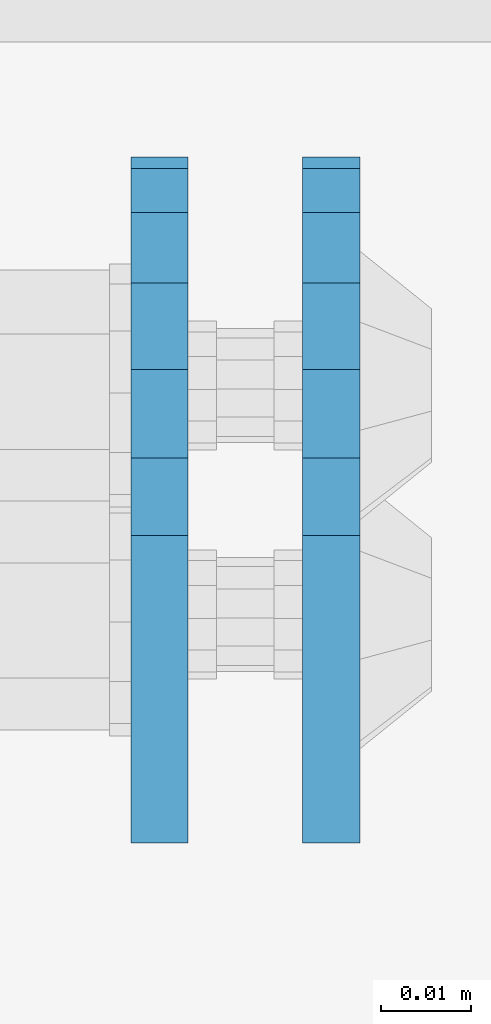
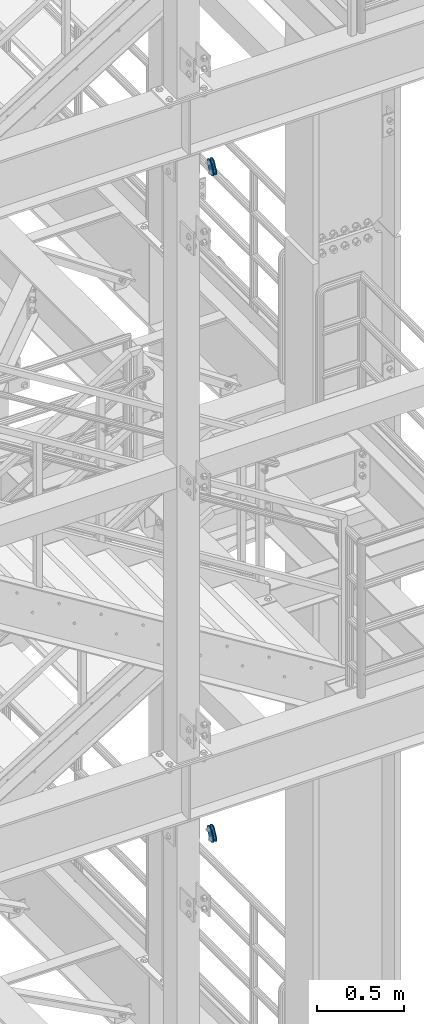
# One storey, part 1445 of 1876: 4 plates, 4 elements without a shape of their own.
"""IFC2X3 building model written with IfcOpenShell, lengths in millimetres."""

from ifc_helpers import new_model, si_unit, frame, origin_with_axes, place, context, subcontext, project, spatial, faceted_brep, material, type_object, element, aggregate, save


model = new_model("IFC2X3")

# Units and contexts
model_context = context("Model", 3, precision=1e-05, world=origin_with_axes())
body_context = subcontext(model_context, "Body", "Model", "MODEL_VIEW")
ifc_project = project(units=[si_unit("LENGTHUNIT", "METRE", prefix="MILLI"), si_unit("AREAUNIT", "SQUARE_METRE"), si_unit("VOLUMEUNIT", "CUBIC_METRE"), si_unit("MASSUNIT", "GRAM", prefix="KILO"), si_unit("TIMEUNIT", "SECOND"), si_unit("PLANEANGLEUNIT", "RADIAN"), si_unit("SOLIDANGLEUNIT", "STERADIAN"), si_unit("THERMODYNAMICTEMPERATUREUNIT", "DEGREE_CELSIUS"), si_unit("LUMINOUSINTENSITYUNIT", "LUMEN")], contexts=[model_context])

# Site, building, storey
site_placement = place(None, origin_with_axes())
site = spatial("IfcSite", under=ifc_project, at=site_placement, CompositionType="ELEMENT")
building_placement = place(site_placement, origin_with_axes())
building = spatial("IfcBuilding", under=site, at=building_placement, Name="Undefined", CompositionType="ELEMENT")
storey_placement = place(building_placement, origin_with_axes())
storey = spatial("IfcBuildingStorey", under=building, at=storey_placement, Name="Undefined", CompositionType="ELEMENT", Elevation=0.0)

# Assembly, plate
assembly_1_placement = place(storey_placement, origin_with_axes())
assembly_1 = element("IfcElementAssembly", 1, at=assembly_1_placement, inside=storey, Name="PLATE", AssemblyPlace="NOTDEFINED", PredefinedType="RIGID_FRAME")
ifc_material = material(Name="STEEL/A36")
plate_type = type_object("IfcPlateType", PredefinedType="NOTDEFINED")
plate_1_placement = place(assembly_1_placement, frame((5086.35, -7466.25922341129, 17725.177677481), z_axis=(0.0, 0.894427191199917, -0.447213595099955), x_axis=(0.0, -0.447213595099955, -0.894427191199917)))
plate_1 = element("IfcPlate", 2, at=plate_1_placement, type_object=plate_type, material=ifc_material, Name="PLATE", context=body_context, shape_type="Brep", body=[
    faceted_brep([(-8.59611645864788e-07, -3.17499999999654, 25.3999987589127), (1.93345873884391, -3.17499999999382, 35.1201580589886), (1.93345873884391, 3.17500000000564, 35.1201580589886), (-8.59611645864788e-07, 3.17500000000382, 25.3999987589132), (7.43948648259902, -3.17499999999109, 43.3605112870105), (7.43948648259902, 3.17500000000928, 43.3605112870105), (15.6798395242777, -3.17499999998654, 48.8665393096448), (15.6798395242777, 3.17500000001382, 48.8665393096448), (25.3999987589095, -3.17499999998199, 50.7999992370592), (25.3999987589095, 3.17500000001837, 50.7999992370592), (82.196130752618, -3.17499999998381, 50.7999992370605), (82.196130752618, 3.17500000001655, 50.7999992370642), (91.9162897887145, -3.17499999997926, 48.8665393918873), (91.9162897887145, 3.1750000000211, 48.8665393918909), (100.156642725027, -3.17499999997472, 43.3605115909359), (100.156642725027, 3.17500000002565, 43.3605115909395), (105.662670525982, -3.17499999997108, 35.1201586546285), (105.662670525986, 3.17500000002929, 35.1201586546358), (107.596130371159, -3.17499999996744, 25.3999996185757), (107.596130371159, 3.17500000003292, 25.3999996185794), (105.662670525981, -3.17499999996471, 15.6798405824902), (105.662670525981, 3.17500000003565, 15.6798405824939), (100.156642725024, -3.17499999996471, 7.43948764618654), (100.156642725025, 3.17500000003565, 7.43948764619017), (91.9162897887127, -3.17499999996562, 1.93345984522784), (91.9162897887127, 3.17500000003474, 1.93345984523148), (82.196130752618, -3.17499999996835, 4.54747350886464e-11), (82.196130752618, 3.1750000000311, 4.91127138957381e-11), (25.399998758905, -3.17499999999018, -8.64019966684282e-12), (25.399998758905, 3.17500000001019, -8.64019966684282e-12), (15.679839921364, -3.17499999999382, 1.9334597629304), (15.679839921364, 3.17500000000655, 1.9334597629304), (7.43948709043525, -3.17499999999654, 7.43948734220839), (7.43948709043525, 3.17500000000382, 7.43948734220885), (1.93345923228208, -3.17499999999654, 15.6798399868012), (1.93345923228208, 3.17500000000291, 15.6798399868012)], [[[0, 1, 2, 3]], [[1, 4, 5, 2]], [[4, 6, 7, 5]], [[6, 8, 9, 7]], [[8, 10, 11, 9]], [[10, 12, 13, 11]], [[12, 14, 15, 13]], [[14, 16, 17, 15]], [[16, 18, 19, 17]], [[18, 20, 21, 19]], [[20, 22, 23, 21]], [[22, 24, 25, 23]], [[24, 26, 27, 25]], [[26, 28, 29, 27]], [[28, 30, 31, 29]], [[30, 32, 33, 31]], [[32, 34, 35, 33]], [[34, 0, 3, 35]], [[5, 7, 9, 11, 13, 15, 17, 19, 21, 23, 25, 27, 29, 31, 33, 35, 3, 2]], [[34, 32, 30, 28, 26, 24, 22, 20, 18, 16, 14, 12, 10, 8, 6, 4, 1, 0]]]),
])
aggregate(assembly_1, [plate_1])

assembly_2_placement = place(storey_placement, origin_with_axes())
assembly_2 = element("IfcElementAssembly", 3, at=assembly_2_placement, inside=storey, Name="PLATE", AssemblyPlace="NOTDEFINED", PredefinedType="RIGID_FRAME")
plate_2_placement = place(assembly_2_placement, frame((5067.28879521564, -7466.25922341129, 17725.177677481), z_axis=(0.0, 0.894427191199917, -0.447213595099955), x_axis=(0.0, -0.447213595099955, -0.894427191199917)))
plate_2 = element("IfcPlate", 4, at=plate_2_placement, type_object=plate_type, material=ifc_material, Name="PLATE", context=body_context, shape_type="Brep", body=[
    faceted_brep([(-8.59611645864788e-07, -3.17499999999654, 25.3999987589127), (1.93345873884391, -3.17499999999382, 35.1201580589886), (1.93345873884391, 3.17500000000564, 35.1201580589886), (-8.59611645864788e-07, 3.17500000000382, 25.3999987589132), (7.43948648259902, -3.17499999999109, 43.3605112870105), (7.43948648259902, 3.17500000000928, 43.3605112870105), (15.6798395242777, -3.17499999998654, 48.8665393096448), (15.6798395242777, 3.17500000001382, 48.8665393096448), (25.3999987589095, -3.17499999998199, 50.7999992370592), (25.3999987589095, 3.17500000001837, 50.7999992370592), (82.196130752618, -3.17499999998381, 50.7999992370605), (82.196130752618, 3.17500000001655, 50.7999992370642), (91.9162897887145, -3.17499999997926, 48.8665393918873), (91.9162897887145, 3.1750000000211, 48.8665393918909), (100.156642725027, -3.17499999997472, 43.3605115909359), (100.156642725027, 3.17500000002565, 43.3605115909395), (105.662670525982, -3.17499999997108, 35.1201586546285), (105.662670525986, 3.17500000002929, 35.1201586546358), (107.596130371159, -3.17499999996744, 25.3999996185757), (107.596130371159, 3.17500000003292, 25.3999996185794), (105.662670525981, -3.17499999996471, 15.6798405824902), (105.662670525981, 3.17500000003565, 15.6798405824939), (100.156642725024, -3.17499999996471, 7.43948764618654), (100.156642725025, 3.17500000003565, 7.43948764619017), (91.9162897887127, -3.17499999996562, 1.93345984522784), (91.9162897887127, 3.17500000003474, 1.93345984523148), (82.196130752618, -3.17499999996835, 4.54747350886464e-11), (82.196130752618, 3.1750000000311, 4.91127138957381e-11), (25.399998758905, -3.17499999999018, -8.64019966684282e-12), (25.399998758905, 3.17500000001019, -8.64019966684282e-12), (15.679839921364, -3.17499999999382, 1.9334597629304), (15.679839921364, 3.17500000000655, 1.9334597629304), (7.43948709043525, -3.17499999999654, 7.43948734220839), (7.43948709043525, 3.17500000000382, 7.43948734220885), (1.93345923228208, -3.17499999999654, 15.6798399868012), (1.93345923228208, 3.17500000000291, 15.6798399868012)], [[[0, 1, 2, 3]], [[1, 4, 5, 2]], [[4, 6, 7, 5]], [[6, 8, 9, 7]], [[8, 10, 11, 9]], [[10, 12, 13, 11]], [[12, 14, 15, 13]], [[14, 16, 17, 15]], [[16, 18, 19, 17]], [[18, 20, 21, 19]], [[20, 22, 23, 21]], [[22, 24, 25, 23]], [[24, 26, 27, 25]], [[26, 28, 29, 27]], [[28, 30, 31, 29]], [[30, 32, 33, 31]], [[32, 34, 35, 33]], [[34, 0, 3, 35]], [[5, 7, 9, 11, 13, 15, 17, 19, 21, 23, 25, 27, 29, 31, 33, 35, 3, 2]], [[34, 32, 30, 28, 26, 24, 22, 20, 18, 16, 14, 12, 10, 8, 6, 4, 1, 0]]]),
])
aggregate(assembly_2, [plate_2])

assembly_3_placement = place(storey_placement, origin_with_axes())
assembly_3 = element("IfcElementAssembly", 5, at=assembly_3_placement, inside=storey, Name="PLATE", AssemblyPlace="NOTDEFINED", PredefinedType="RIGID_FRAME")
plate_3_placement = place(assembly_3_placement, frame((5086.35, -7466.25922341129, 13038.8776774809), z_axis=(0.0, 0.894427191199917, -0.447213595099955), x_axis=(0.0, -0.447213595099955, -0.894427191199917)))
plate_3 = element("IfcPlate", 6, at=plate_3_placement, type_object=plate_type, material=ifc_material, Name="PLATE", context=body_context, shape_type="Brep", body=[
    faceted_brep([(-8.59611645864788e-07, -3.17499999999654, 25.3999987589127), (1.93345873884391, -3.17499999999382, 35.1201580589886), (1.93345873884391, 3.17500000000564, 35.1201580589886), (-8.59611645864788e-07, 3.17500000000382, 25.3999987589132), (7.43948648259902, -3.17499999999109, 43.3605112870105), (7.43948648259902, 3.17500000000928, 43.3605112870105), (15.6798395242777, -3.17499999998654, 48.8665393096448), (15.6798395242777, 3.17500000001382, 48.8665393096448), (25.3999987589095, -3.17499999998199, 50.7999992370592), (25.3999987589095, 3.17500000001837, 50.7999992370592), (82.196130752618, -3.17499999998381, 50.7999992370605), (82.196130752618, 3.17500000001655, 50.7999992370642), (91.9162897887145, -3.17499999997926, 48.8665393918873), (91.9162897887145, 3.1750000000211, 48.8665393918909), (100.156642725027, -3.17499999997472, 43.3605115909359), (100.156642725027, 3.17500000002565, 43.3605115909395), (105.662670525982, -3.17499999997108, 35.1201586546285), (105.662670525986, 3.17500000002929, 35.1201586546358), (107.596130371159, -3.17499999996744, 25.3999996185757), (107.596130371159, 3.17500000003292, 25.3999996185794), (105.662670525981, -3.17499999996471, 15.6798405824902), (105.662670525981, 3.17500000003565, 15.6798405824939), (100.156642725024, -3.17499999996471, 7.43948764618654), (100.156642725025, 3.17500000003565, 7.43948764619017), (91.9162897887127, -3.17499999996562, 1.93345984522784), (91.9162897887127, 3.17500000003474, 1.93345984523148), (82.196130752618, -3.17499999996835, 4.54747350886464e-11), (82.196130752618, 3.1750000000311, 4.91127138957381e-11), (25.399998758905, -3.17499999999018, -8.64019966684282e-12), (25.399998758905, 3.17500000001019, -8.64019966684282e-12), (15.679839921364, -3.17499999999382, 1.9334597629304), (15.679839921364, 3.17500000000655, 1.9334597629304), (7.43948709043525, -3.17499999999654, 7.43948734220839), (7.43948709043525, 3.17500000000382, 7.43948734220885), (1.93345923228208, -3.17499999999654, 15.6798399868012), (1.93345923228208, 3.17500000000291, 15.6798399868012)], [[[0, 1, 2, 3]], [[1, 4, 5, 2]], [[4, 6, 7, 5]], [[6, 8, 9, 7]], [[8, 10, 11, 9]], [[10, 12, 13, 11]], [[12, 14, 15, 13]], [[14, 16, 17, 15]], [[16, 18, 19, 17]], [[18, 20, 21, 19]], [[20, 22, 23, 21]], [[22, 24, 25, 23]], [[24, 26, 27, 25]], [[26, 28, 29, 27]], [[28, 30, 31, 29]], [[30, 32, 33, 31]], [[32, 34, 35, 33]], [[34, 0, 3, 35]], [[5, 7, 9, 11, 13, 15, 17, 19, 21, 23, 25, 27, 29, 31, 33, 35, 3, 2]], [[34, 32, 30, 28, 26, 24, 22, 20, 18, 16, 14, 12, 10, 8, 6, 4, 1, 0]]]),
])
aggregate(assembly_3, [plate_3])

assembly_4_placement = place(storey_placement, origin_with_axes())
assembly_4 = element("IfcElementAssembly", 7, at=assembly_4_placement, inside=storey, Name="PLATE", AssemblyPlace="NOTDEFINED", PredefinedType="RIGID_FRAME")
plate_4_placement = place(assembly_4_placement, frame((5067.28879521564, -7466.25922341129, 13038.8776774809), z_axis=(0.0, 0.894427191199917, -0.447213595099955), x_axis=(0.0, -0.447213595099955, -0.894427191199917)))
plate_4 = element("IfcPlate", 8, at=plate_4_placement, type_object=plate_type, material=ifc_material, Name="PLATE", context=body_context, shape_type="Brep", body=[
    faceted_brep([(-8.59611645864788e-07, -3.17499999999654, 25.3999987589127), (1.93345873884391, -3.17499999999382, 35.1201580589886), (1.93345873884391, 3.17500000000564, 35.1201580589886), (-8.59611645864788e-07, 3.17500000000382, 25.3999987589132), (7.43948648259902, -3.17499999999109, 43.3605112870105), (7.43948648259902, 3.17500000000928, 43.3605112870105), (15.6798395242777, -3.17499999998654, 48.8665393096448), (15.6798395242777, 3.17500000001382, 48.8665393096448), (25.3999987589095, -3.17499999998199, 50.7999992370592), (25.3999987589095, 3.17500000001837, 50.7999992370592), (82.196130752618, -3.17499999998381, 50.7999992370605), (82.196130752618, 3.17500000001655, 50.7999992370642), (91.9162897887145, -3.17499999997926, 48.8665393918873), (91.9162897887145, 3.1750000000211, 48.8665393918909), (100.156642725027, -3.17499999997472, 43.3605115909359), (100.156642725027, 3.17500000002565, 43.3605115909395), (105.662670525982, -3.17499999997108, 35.1201586546285), (105.662670525986, 3.17500000002929, 35.1201586546358), (107.596130371159, -3.17499999996744, 25.3999996185757), (107.596130371159, 3.17500000003292, 25.3999996185794), (105.662670525981, -3.17499999996471, 15.6798405824902), (105.662670525981, 3.17500000003565, 15.6798405824939), (100.156642725024, -3.17499999996471, 7.43948764618654), (100.156642725025, 3.17500000003565, 7.43948764619017), (91.9162897887127, -3.17499999996562, 1.93345984522784), (91.9162897887127, 3.17500000003474, 1.93345984523148), (82.196130752618, -3.17499999996835, 4.54747350886464e-11), (82.196130752618, 3.1750000000311, 4.91127138957381e-11), (25.399998758905, -3.17499999999018, -8.64019966684282e-12), (25.399998758905, 3.17500000001019, -8.64019966684282e-12), (15.679839921364, -3.17499999999382, 1.9334597629304), (15.679839921364, 3.17500000000655, 1.9334597629304), (7.43948709043525, -3.17499999999654, 7.43948734220839), (7.43948709043525, 3.17500000000382, 7.43948734220885), (1.93345923228208, -3.17499999999654, 15.6798399868012), (1.93345923228208, 3.17500000000291, 15.6798399868012)], [[[0, 1, 2, 3]], [[1, 4, 5, 2]], [[4, 6, 7, 5]], [[6, 8, 9, 7]], [[8, 10, 11, 9]], [[10, 12, 13, 11]], [[12, 14, 15, 13]], [[14, 16, 17, 15]], [[16, 18, 19, 17]], [[18, 20, 21, 19]], [[20, 22, 23, 21]], [[22, 24, 25, 23]], [[24, 26, 27, 25]], [[26, 28, 29, 27]], [[28, 30, 31, 29]], [[30, 32, 33, 31]], [[32, 34, 35, 33]], [[34, 0, 3, 35]], [[5, 7, 9, 11, 13, 15, 17, 19, 21, 23, 25, 27, 29, 31, 33, 35, 3, 2]], [[34, 32, 30, 28, 26, 24, 22, 20, 18, 16, 14, 12, 10, 8, 6, 4, 1, 0]]]),
])
aggregate(assembly_4, [plate_4])

save(model, "model.ifc")
